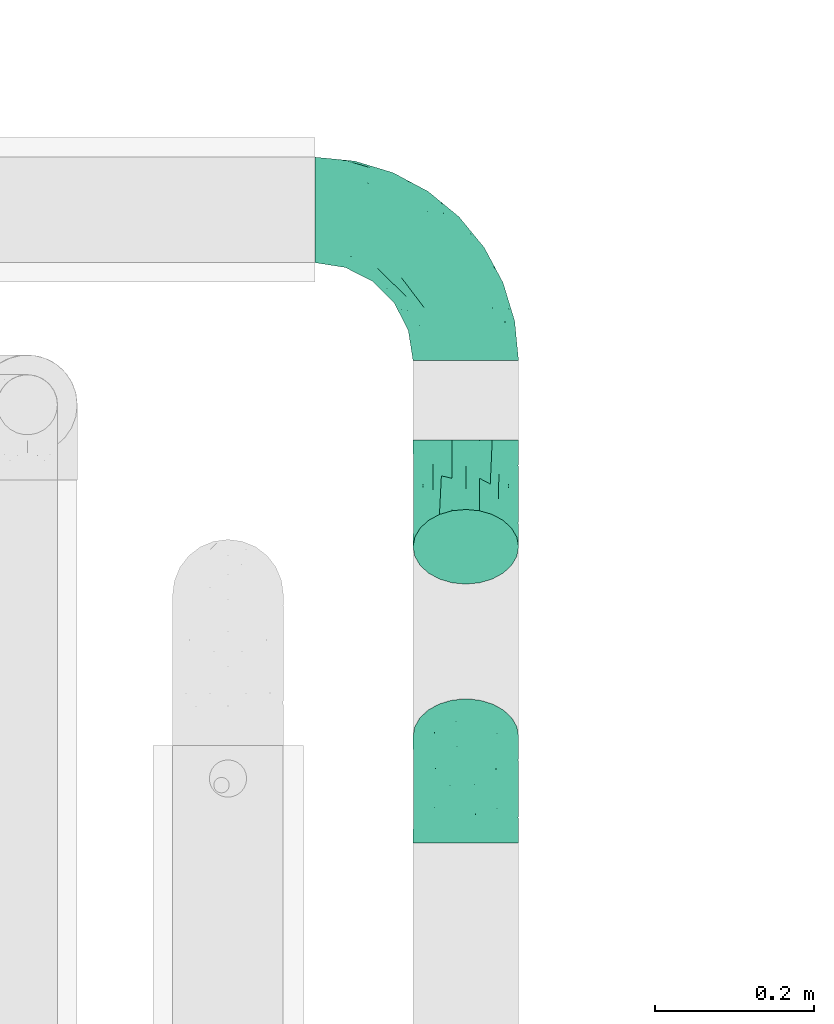
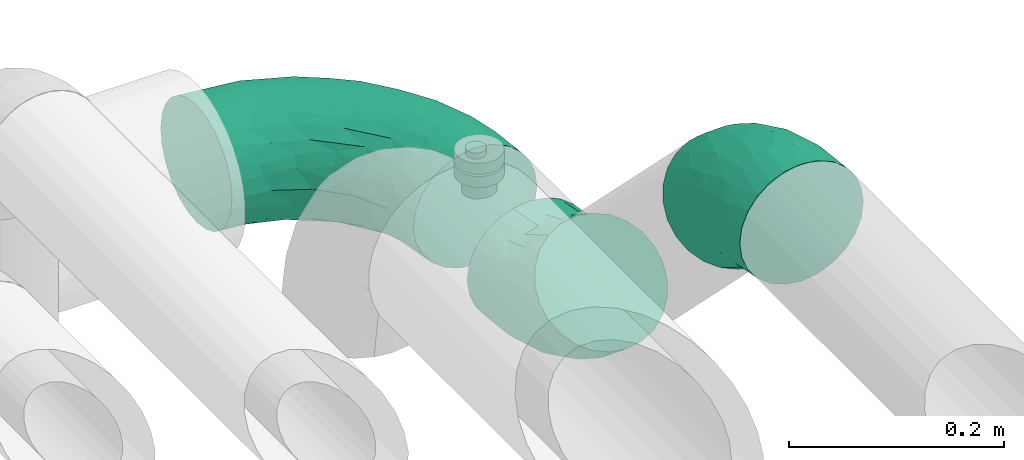
# One storey, part 560 of 827: 3 flow fittings.
"""IFC2X3 building model written with IfcOpenShell, lengths in millimetres."""

from ifc_helpers import new_model, entity, si_unit, converted_unit, derived_unit, direction, frame, origin, place, context, subcontext, project, spatial, faceted_brep, source, transform, mapped, material, type_object, type_shapes, element, save


model = new_model("IFC2X3")

# Units and contexts
model_context = context("Model", 3, precision=0.01, world=origin(), true_north=direction((6.12303176911189e-17, 1.0)))
body_context = subcontext(model_context, "Body", "Model", "MODEL_VIEW")
ifc_project = project(units=[si_unit("LENGTHUNIT", "METRE", prefix="MILLI"), si_unit("AREAUNIT", "SQUARE_METRE"), si_unit("VOLUMEUNIT", "CUBIC_METRE"), converted_unit("PLANEANGLEUNIT", "DEGREE", entity("IfcRatioMeasure", 0.0174532925199433), si_unit("PLANEANGLEUNIT", "RADIAN"), dimensions=[0, 0, 0, 0, 0, 0, 0]), si_unit("MASSUNIT", "GRAM", prefix="KILO"), derived_unit("MASSDENSITYUNIT", [(si_unit("MASSUNIT", "GRAM", prefix="KILO"), 1), (si_unit("LENGTHUNIT", "METRE"), -3)]), derived_unit("MOMENTOFINERTIAUNIT", [(si_unit("LENGTHUNIT", "METRE"), 4)]), si_unit("TIMEUNIT", "SECOND"), si_unit("FREQUENCYUNIT", "HERTZ"), si_unit("THERMODYNAMICTEMPERATUREUNIT", "DEGREE_CELSIUS"), derived_unit("THERMALTRANSMITTANCEUNIT", [(si_unit("MASSUNIT", "GRAM", prefix="KILO"), 1), (si_unit("THERMODYNAMICTEMPERATUREUNIT", "KELVIN"), -1), (si_unit("TIMEUNIT", "SECOND"), -3)]), derived_unit("VOLUMETRICFLOWRATEUNIT", [(si_unit("LENGTHUNIT", "METRE"), 3), (si_unit("TIMEUNIT", "SECOND"), -1)]), derived_unit("MASSFLOWRATEUNIT", [(si_unit("MASSUNIT", "GRAM", prefix="KILO"), 1), (si_unit("TIMEUNIT", "SECOND"), -1)]), derived_unit("ROTATIONALFREQUENCYUNIT", [(si_unit("TIMEUNIT", "SECOND"), -1)]), si_unit("ELECTRICCURRENTUNIT", "AMPERE"), si_unit("ELECTRICVOLTAGEUNIT", "VOLT"), si_unit("POWERUNIT", "WATT"), si_unit("FORCEUNIT", "NEWTON", prefix="KILO"), si_unit("ILLUMINANCEUNIT", "LUX"), si_unit("LUMINOUSFLUXUNIT", "LUMEN"), si_unit("LUMINOUSINTENSITYUNIT", "CANDELA"), derived_unit("USERDEFINED", [(si_unit("MASSUNIT", "GRAM", prefix="KILO"), -1), (si_unit("LENGTHUNIT", "METRE"), -2), (si_unit("TIMEUNIT", "SECOND"), 3), (si_unit("LUMINOUSFLUXUNIT", "LUMEN"), 1)]), derived_unit("LINEARVELOCITYUNIT", [(si_unit("LENGTHUNIT", "METRE"), 1), (si_unit("TIMEUNIT", "SECOND"), -1)]), si_unit("PRESSUREUNIT", "PASCAL"), derived_unit("USERDEFINED", [(si_unit("LENGTHUNIT", "METRE"), -2), (si_unit("MASSUNIT", "GRAM", prefix="KILO"), 1), (si_unit("TIMEUNIT", "SECOND"), -2)]), derived_unit("LINEARFORCEUNIT", [(si_unit("MASSUNIT", "GRAM", prefix="KILO"), 1), (si_unit("LENGTHUNIT", "METRE"), 1), (si_unit("TIMEUNIT", "SECOND"), -2), (si_unit("LENGTHUNIT", "METRE"), -1)]), derived_unit("PLANARFORCEUNIT", [(si_unit("MASSUNIT", "GRAM", prefix="KILO"), 1), (si_unit("LENGTHUNIT", "METRE"), 1), (si_unit("TIMEUNIT", "SECOND"), -2), (si_unit("LENGTHUNIT", "METRE"), -2)])], contexts=[model_context])

# Site, building, storey
site_placement = place(None, origin())
site = spatial("IfcSite", under=ifc_project, at=site_placement, CompositionType="ELEMENT")
building_placement = place(site_placement, origin())
building = spatial("IfcBuilding", under=site, at=building_placement, CompositionType="ELEMENT")
storey_placement = place(building_placement, frame((0.0, 0.0, 28200.0)))
storey = spatial("IfcBuildingStorey", under=building, at=storey_placement, Name="08", CompositionType="ELEMENT", Elevation=28200.0)

# Flow fittings
ifc_material = material()
pipe_fitting_type_1 = type_object("IfcPipeFittingType", Name="ADSK_2", PredefinedType="NOTDEFINED", material=ifc_material)
shared_shape_1 = source(origin(), body_context, "Body", "Brep", [
    faceted_brep([(-190.0, 33.25, -57.59), (-190.0, 17.21, -64.23), (-190.0, 0.0, -66.5), (-190.0, -17.21, -64.23), (-190.0, -33.25, -57.59), (-190.0, -47.02, -47.02), (-190.0, -57.59, -33.25), (-190.0, -64.23, -17.21), (-190.0, -66.5, 0.0), (-190.0, -64.23, 17.21), (-190.0, -57.59, 33.25), (-190.0, -47.02, 47.02), (-190.0, -33.25, 57.59), (-190.0, -17.21, 64.23), (-190.0, 0.0, 66.5), (-190.0, 17.21, 64.23), (-190.0, 33.25, 57.59), (-190.0, 47.02, 47.02), (-190.0, 57.59, 33.25), (-190.0, 64.23, 17.21), (-190.0, 66.5, 0.0), (-190.0, 64.23, -17.21), (-190.0, 57.59, -33.25), (-190.0, 47.02, -47.02), (0.0, 190.0, -66.5), (-17.21, 190.0, -64.23), (-33.25, 190.0, -57.59), (-47.02, 190.0, -47.02), (-57.59, 190.0, -33.25), (-64.23, 190.0, -17.21), (-66.5, 190.0, 0.0), (-64.23, 190.0, 17.21), (-57.59, 190.0, 33.25), (-47.02, 190.0, 47.02), (-33.25, 190.0, 57.59), (-17.21, 190.0, 64.23), (0.0, 190.0, 66.5), (17.21, 190.0, 64.23), (33.25, 190.0, 57.59), (47.02, 190.0, 47.02), (57.59, 190.0, 33.25), (64.23, 190.0, 17.21), (66.5, 190.0, 0.0), (64.23, 190.0, -17.21), (57.59, 190.0, -33.25), (47.02, 190.0, -47.02), (33.25, 190.0, -57.59), (17.21, 190.0, -64.23), (-28.55, 147.02, 62.42), (-13.57, 135.63, 66.28), (-140.38, -49.33, 38.23), (-80.14, -30.55, 35.23), (-124.14, -33.9, 50.4), (-141.11, -22.46, 60.31), (-81.84, -6.19, 57.13), (-101.3, 6.38, 65.03), (-125.04, -54.28, 21.95), (-139.96, -61.57, 0.0), (-30.59, -6.47, 21.28), (-47.5, -23.27, 0.0), (-8.63, 8.63, 0.0), (-101.64, 52.37, 61.01), (-147.02, 28.55, 62.42), (-107.01, 35.47, 64.88), (-72.79, -35.94, 16.05), (-91.84, -46.98, 0.0), (-42.05, -7.73, 34.33), (-4.24, 27.9, 35.0), (-46.26, 0.22, 45.96), (-148.38, -6.74, 65.57), (-135.63, 13.57, 66.28), (-58.81, 143.49, 42.9), (-64.43, 158.86, 27.32), (33.87, 124.03, 50.39), (-24.86, 95.88, 66.5), (-6.38, 101.3, 65.03), (-68.44, 29.45, 65.52), (-33.12, 50.38, 63.42), (-47.55, 58.11, 66.37), (-68.78, 157.93, 15.75), (-78.73, 128.81, 21.25), (-145.19, 58.3, 42.81), (-126.57, 73.12, 34.22), (-158.86, 64.43, 27.32), (-157.93, 68.78, 15.75), (-73.06, 126.96, 34.0), (-99.23, 99.23, 24.99), (-94.51, 94.51, 37.44), (-160.28, 41.89, 53.91), (-151.84, 72.54, 0.0), (-128.81, 78.73, 21.25), (-117.41, 90.09, 0.0), (7.42, 29.34, 16.05), (36.05, 72.53, 15.16), (23.27, 47.5, 0.0), (30.73, 80.34, 35.12), (61.57, 139.96, 0.0), (62.07, 150.38, 13.25), (46.98, 91.84, 0.0), (22.46, 141.08, 60.31), (6.16, 81.82, 57.15), (-39.4, 100.2, 64.86), (54.07, 123.33, 21.27), (49.32, 140.35, 38.22), (-83.36, -19.52, 48.87), (6.74, 148.38, 65.57), (-85.07, 81.39, 53.88), (-123.92, 51.92, 55.31), (-90.09, 117.41, 0.0), (-72.54, 151.84, 0.0), (-101.92, 101.92, 11.85), (-42.36, 157.28, 54.02), (-54.08, 118.94, 55.5), (-1.97, 47.81, 48.28), (22.27, 83.36, 46.49), (-79.1, 73.18, 59.88), (-73.69, 63.3, 64.01), (-96.26, 24.55, 66.5), (-73.56, 111.53, 44.32), (-111.08, 72.88, 45.21), (-31.39, 31.39, 56.96), (-71.89, 12.15, 62.21), (-42.48, 117.92, 61.28), (-157.28, 42.36, -54.02), (-72.79, -35.94, -16.05), (-44.48, -10.39, -33.14), (-30.59, -6.47, -21.28), (-101.3, 6.38, -65.03), (-148.38, -6.74, -65.57), (-135.63, 13.57, -66.28), (-157.93, 68.78, -15.75), (-128.81, 78.73, -21.25), (-158.86, 64.43, -27.32), (-147.02, 28.55, -62.42), (-100.2, 39.4, -64.86), (-95.88, 24.86, -66.5), (-150.3, -62.06, -13.27), (-101.92, 101.92, -11.85), (-143.49, 58.81, -42.9), (6.74, 148.38, -65.57), (-13.57, 135.63, -66.28), (-52.37, 101.64, -61.01), (-81.39, 85.07, -53.88), (-51.92, 123.92, -55.31), (-124.14, -33.9, -50.4), (-81.84, -6.19, -57.13), (-78.6, -18.73, -47.44), (-140.38, -49.33, -38.23), (-24.55, 96.26, -66.5), (-35.47, 107.01, -64.88), (-28.55, 147.02, -62.42), (-80.14, -30.55, -35.23), (-123.37, -54.04, -21.36), (-64.43, 158.86, -27.32), (-68.78, 157.93, -15.75), (-73.18, 79.1, -59.88), (-63.3, 73.69, -64.01), (-29.45, 68.44, -65.52), (-50.38, 33.12, -63.42), (-58.11, 47.55, -66.37), (-78.73, 128.81, -21.25), (-99.23, 99.23, -24.99), (-126.96, 73.06, -34.0), (-94.51, 94.51, -37.44), (-58.3, 145.19, -42.81), (-73.12, 126.57, -34.22), (-118.94, 54.08, -55.5), (-41.89, 160.28, -53.91), (22.46, 141.08, -60.31), (6.16, 81.82, -57.15), (-6.38, 101.3, -65.03), (33.87, 124.03, -50.39), (54.35, 125.32, -21.97), (35.86, 72.99, -16.69), (49.34, 140.46, -38.23), (7.54, 29.16, -15.21), (-141.11, -22.46, -60.31), (30.73, 80.34, -35.12), (22.8, 84.14, -46.35), (-4.38, 23.43, -29.89), (5.33, 47.62, -41.81), (-111.53, 73.56, -44.32), (-72.88, 111.08, -45.21), (-48.51, 2.91, -49.35), (-20.15, 28.66, -49.63), (-27.46, 10.86, -41.59), (-12.16, 71.91, -62.22), (2.48, 58.84, -50.8), (-117.92, 42.48, -61.28), (-31.39, 31.39, -56.96)], [[[0, 1, 2, 3, 4, 5, 6, 7, 8, 9, 10, 11, 12, 13, 14, 15, 16, 17, 18, 19, 20, 21, 22, 23]], [[24, 25, 26, 27, 28, 29, 30, 31, 32, 33, 34, 35, 36, 37, 38, 39, 40, 41, 42, 43, 44, 45, 46, 47]], [[35, 48, 49]], [[50, 51, 52]], [[53, 54, 55]], [[56, 10, 9]], [[9, 8, 57]], [[58, 59, 60]], [[56, 50, 10]], [[61, 62, 63]], [[64, 65, 59]], [[58, 64, 59]], [[12, 11, 52]], [[66, 67, 68]], [[52, 53, 12]], [[69, 70, 14]], [[71, 32, 72]], [[73, 39, 38]], [[49, 74, 75]], [[62, 16, 15]], [[14, 70, 15]], [[72, 32, 31]], [[13, 69, 14]], [[76, 77, 78]], [[79, 80, 72]], [[81, 82, 83]], [[62, 15, 70]], [[20, 19, 84]], [[85, 86, 87]], [[81, 17, 88]], [[89, 90, 91]], [[19, 83, 84]], [[16, 88, 17]], [[85, 71, 72]], [[58, 60, 92]], [[49, 36, 35]], [[93, 92, 94]], [[35, 34, 48]], [[92, 93, 95]], [[96, 97, 98]], [[73, 99, 100]], [[49, 101, 74]], [[102, 97, 40]], [[39, 73, 103]], [[95, 102, 103]], [[40, 39, 103]], [[12, 53, 13]], [[68, 54, 104]], [[42, 97, 96]], [[41, 97, 42]], [[99, 38, 37]], [[37, 36, 105]], [[61, 106, 107]], [[108, 80, 109]], [[10, 50, 11]], [[108, 91, 110]], [[109, 79, 30]], [[64, 51, 56]], [[71, 33, 32]], [[86, 110, 90]], [[92, 60, 94]], [[111, 34, 33]], [[71, 112, 111]], [[49, 48, 101]], [[9, 57, 56]], [[17, 81, 18]], [[65, 56, 57]], [[113, 114, 100]], [[75, 105, 49]], [[115, 61, 116]], [[58, 92, 67]], [[99, 73, 38]], [[70, 117, 63]], [[18, 83, 19]], [[71, 85, 118]], [[119, 107, 106]], [[83, 82, 90]], [[51, 50, 56]], [[52, 11, 50]], [[51, 64, 58]], [[56, 65, 64]], [[94, 98, 93]], [[67, 92, 95]], [[95, 114, 113]], [[68, 120, 54]], [[54, 53, 52]], [[69, 53, 55]], [[104, 51, 68]], [[121, 76, 55]], [[103, 73, 114]], [[102, 40, 103]], [[105, 99, 37]], [[75, 77, 100]], [[75, 100, 99]], [[100, 120, 113]], [[111, 48, 34]], [[115, 101, 122]], [[122, 101, 48]], [[101, 116, 78]], [[116, 63, 117]], [[78, 117, 76]], [[63, 62, 70]], [[88, 62, 107]], [[98, 102, 93]], [[95, 93, 102]], [[66, 68, 51]], [[113, 68, 67]], [[49, 105, 36]], [[99, 105, 75]], [[53, 69, 13]], [[70, 69, 55]], [[70, 55, 117]], [[61, 63, 116]], [[76, 117, 55]], [[116, 117, 78]], [[121, 55, 54]], [[76, 121, 77]], [[100, 77, 120]], [[75, 78, 77]], [[54, 120, 121]], [[77, 121, 120]], [[71, 111, 33]], [[111, 112, 122]], [[68, 113, 120]], [[95, 113, 67]], [[61, 115, 106]], [[62, 61, 107]], [[118, 112, 71]], [[119, 87, 82]], [[101, 115, 116]], [[112, 106, 115]], [[79, 72, 31]], [[72, 80, 85]], [[86, 85, 80]], [[118, 85, 87]], [[119, 118, 87]], [[112, 118, 106]], [[30, 79, 31]], [[109, 80, 79]], [[81, 83, 18]], [[84, 83, 90]], [[119, 82, 81]], [[86, 82, 87]], [[107, 119, 81]], [[118, 119, 106]], [[90, 89, 84]], [[20, 84, 89]], [[62, 88, 16]], [[81, 88, 107]], [[101, 78, 74]], [[78, 75, 74]], [[80, 108, 110]], [[82, 86, 90]], [[90, 110, 91]], [[80, 110, 86]], [[40, 97, 41]], [[98, 97, 102]], [[111, 122, 48]], [[115, 122, 112]], [[54, 52, 104]], [[51, 104, 52]], [[51, 58, 66]], [[67, 66, 58]], [[103, 114, 95]], [[100, 114, 73]], [[23, 123, 0]], [[124, 125, 126]], [[127, 128, 129]], [[130, 131, 132]], [[133, 134, 129]], [[129, 135, 127]], [[89, 130, 20]], [[8, 136, 57]], [[91, 131, 89]], [[59, 65, 124]], [[108, 137, 91]], [[132, 22, 21]], [[138, 23, 22]], [[139, 140, 24]], [[141, 142, 143]], [[144, 145, 146]], [[5, 144, 147]], [[140, 148, 149]], [[8, 7, 136]], [[138, 22, 132]], [[6, 5, 147]], [[141, 150, 149]], [[147, 151, 152]], [[152, 136, 6]], [[29, 153, 154]], [[125, 124, 151]], [[136, 65, 57]], [[155, 141, 156]], [[128, 3, 2]], [[126, 59, 124]], [[129, 134, 135]], [[157, 158, 159]], [[160, 161, 137]], [[1, 0, 133]], [[129, 2, 1]], [[162, 138, 132]], [[161, 163, 162]], [[154, 30, 29]], [[144, 5, 4]], [[153, 164, 165]], [[150, 26, 25]], [[166, 123, 138]], [[24, 47, 139]], [[24, 140, 25]], [[28, 153, 29]], [[26, 167, 27]], [[168, 169, 170]], [[140, 150, 25]], [[27, 164, 28]], [[46, 171, 168]], [[172, 98, 173]], [[59, 126, 60]], [[27, 167, 164]], [[44, 174, 45]], [[173, 98, 94]], [[175, 173, 94]], [[176, 144, 4]], [[171, 46, 45]], [[44, 43, 172]], [[43, 96, 172]], [[42, 96, 43]], [[144, 146, 151]], [[144, 176, 145]], [[177, 178, 174]], [[173, 175, 179]], [[44, 172, 174]], [[98, 172, 96]], [[1, 133, 129]], [[179, 180, 177]], [[109, 160, 108]], [[46, 168, 47]], [[176, 4, 3]], [[138, 162, 181]], [[182, 143, 142]], [[153, 165, 160]], [[94, 60, 175]], [[177, 172, 173]], [[151, 147, 144]], [[152, 6, 147]], [[128, 176, 3]], [[127, 158, 145]], [[127, 145, 176]], [[183, 184, 185]], [[65, 152, 124]], [[151, 124, 152]], [[177, 174, 172]], [[171, 45, 174]], [[169, 168, 171]], [[139, 168, 170]], [[178, 177, 180]], [[186, 157, 170]], [[187, 169, 178]], [[126, 179, 175]], [[123, 133, 0]], [[155, 134, 188]], [[188, 134, 133]], [[134, 156, 159]], [[156, 149, 148]], [[159, 148, 157]], [[149, 150, 140]], [[167, 150, 143]], [[60, 126, 175]], [[125, 179, 126]], [[129, 128, 2]], [[176, 128, 127]], [[168, 139, 47]], [[140, 139, 170]], [[140, 170, 148]], [[141, 149, 156]], [[157, 148, 170]], [[156, 148, 159]], [[186, 170, 169]], [[157, 186, 158]], [[145, 158, 189]], [[127, 159, 158]], [[169, 189, 186]], [[158, 186, 189]], [[180, 179, 185]], [[173, 179, 177]], [[187, 184, 189]], [[178, 171, 174]], [[187, 178, 180]], [[169, 171, 178]], [[184, 180, 185]], [[189, 169, 187]], [[138, 123, 23]], [[123, 166, 188]], [[141, 155, 142]], [[150, 141, 143]], [[181, 166, 138]], [[182, 163, 165]], [[134, 155, 156]], [[166, 142, 155]], [[130, 132, 21]], [[132, 131, 162]], [[161, 162, 131]], [[181, 162, 163]], [[182, 181, 163]], [[166, 181, 142]], [[20, 130, 21]], [[89, 131, 130]], [[164, 153, 28]], [[154, 153, 160]], [[182, 165, 164]], [[161, 165, 163]], [[143, 182, 164]], [[181, 182, 142]], [[160, 109, 154]], [[30, 154, 109]], [[150, 167, 26]], [[164, 167, 143]], [[134, 159, 135]], [[159, 127, 135]], [[131, 91, 137]], [[165, 161, 160]], [[160, 137, 108]], [[131, 137, 161]], [[6, 136, 7]], [[65, 136, 152]], [[183, 189, 184]], [[146, 183, 125]], [[146, 125, 151]], [[179, 125, 185]], [[123, 188, 133]], [[155, 188, 166]], [[180, 184, 187]], [[185, 125, 183]], [[146, 145, 183]], [[189, 183, 145]]]),
])
type_shapes(pipe_fitting_type_1, [shared_shape_1])
flow_fitting_placement = place(storey_placement, frame((27420.03, 12315.57, 3100.0), z_axis=(0.0, 0.0, 1.0), x_axis=(0.0, 1.0, 0.0)))
element("IfcFlowFitting", 1, at=flow_fitting_placement, inside=storey, type_object=pipe_fitting_type_1, material=ifc_material, Name="ADSK_2", ObjectType="ADSK_2", context=body_context, shape_type="MappedRepresentation", body=[
    mapped(shared_shape_1, transform((0.0, 0.0, 0.0), scale=1.0)),
])
pipe_fitting_type_2 = type_object("IfcPipeFittingType", Name="ADSK_2", PredefinedType="NOTDEFINED", material=ifc_material)
shared_shape_2 = source(origin(), body_context, "Body", "Brep", [
    faceted_brep([(-78.7, 33.25, -57.59), (-78.7, 17.21, -64.23), (-78.7, 0.0, -66.5), (-78.7, -17.21, -64.23), (-78.7, -33.25, -57.59), (-78.7, -47.02, -47.02), (-78.7, -57.59, -33.25), (-78.7, -64.23, -17.21), (-78.7, -66.5, 0.0), (-78.7, -64.23, 17.21), (-78.7, -57.59, 33.25), (-78.7, -47.02, 47.02), (-78.7, -33.25, 57.59), (-78.7, -17.21, 64.23), (-78.7, 0.0, 66.5), (-78.7, 17.21, 64.23), (-78.7, 33.25, 57.59), (-78.7, 47.02, 47.02), (-78.7, 57.59, 33.25), (-78.7, 64.23, 17.21), (-78.7, 66.5, 0.0), (-78.7, 64.23, -17.21), (-78.7, 57.59, -33.25), (-78.7, 47.02, -47.02), (55.65, 55.65, -66.5), (43.48, 67.82, -64.23), (32.14, 79.16, -57.59), (22.4, 88.9, -47.02), (14.93, 96.37, -33.25), (10.23, 101.07, -17.21), (8.63, 102.67, 0.0), (10.23, 101.07, 17.21), (14.93, 96.37, 33.25), (22.4, 88.9, 47.02), (32.14, 79.16, 57.59), (43.48, 67.82, 64.23), (55.65, 55.65, 66.5), (67.82, 43.48, 64.23), (79.16, 32.14, 57.59), (88.9, 22.4, 47.02), (96.37, 14.93, 33.25), (101.07, 10.23, 17.21), (102.67, 8.63, 0.0), (101.07, 10.23, -17.21), (96.37, 14.93, -33.25), (88.9, 22.4, -47.02), (79.16, 32.14, -57.59), (67.82, 43.48, -64.23), (-40.01, -57.38, 27.86), (-40.6, -61.75, 15.74), (-6.41, -52.87, 20.07), (-28.66, -61.57, 0.0), (44.74, 12.16, 61.0), (-23.71, -35.12, 51.77), (8.73, -21.07, 54.25), (-40.23, -23.04, 61.0), (-34.61, -49.5, 39.47), (-28.9, -3.87, 65.72), (-8.47, 20.45, 66.18), (-47.15, 10.46, 66.05), (-49.81, 55.22, 41.25), (-33.77, 66.88, 30.79), (-20.88, 50.42, 53.92), (7.4, 48.4, 61.91), (-34.71, 30.07, 61.97), (42.4, -35.06, 11.04), (19.46, -46.98, 0.0), (63.8, -23.27, 0.0), (-15.18, 67.35, 41.6), (14.82, -35.78, 38.27), (53.98, -24.32, 23.88), (-30.55, 73.76, 17.41), (-46.74, 70.71, 0.0), (59.47, -10.53, 39.47), (-16.95, 83.05, 0.0), (25.95, 40.74, 66.05), (41.59, -8.07, 51.77), (23.18, 17.7, 65.72), (74.36, -14.41, 12.26), (4.62, -11.15, 60.44), (-39.45, 28.99, -61.91), (-20.88, 50.42, -53.92), (3.28, 45.81, -61.97), (-23.41, 71.18, -30.79), (8.73, -21.07, -54.25), (4.62, -11.15, -60.44), (44.74, 12.16, -61.0), (-30.55, 73.76, -17.41), (-40.23, -23.04, -61.0), (-23.71, -35.12, -51.77), (-36.89, 58.36, -41.6), (-47.15, 10.46, -66.05), (-28.9, -3.87, -65.72), (-20.98, -55.37, -23.88), (-34.61, -49.5, -39.47), (68.86, -12.28, -27.86), (59.47, -10.53, -39.47), (-42.39, -62.77, -12.26), (41.59, -8.07, -51.77), (14.82, -35.78, -38.27), (41.92, -32.85, -20.07), (-5.19, -54.78, -11.04), (72.37, -14.95, -15.74), (-3.83, 74.27, -41.25), (25.95, 40.74, -66.05), (23.18, 17.7, -65.72), (-8.47, 20.45, -66.18)], [[[0, 1, 2, 3, 4, 5, 6, 7, 8, 9, 10, 11, 12, 13, 14, 15, 16, 17, 18, 19, 20, 21, 22, 23]], [[24, 25, 26, 27, 28, 29, 30, 31, 32, 33, 34, 35, 36, 37, 38, 39, 40, 41, 42, 43, 44, 45, 46, 47]], [[48, 49, 50]], [[49, 8, 51]], [[38, 37, 52]], [[12, 11, 53]], [[53, 54, 55]], [[56, 11, 10]], [[14, 13, 57]], [[13, 12, 55]], [[57, 58, 59]], [[60, 61, 18]], [[62, 63, 34]], [[18, 61, 19]], [[16, 15, 64]], [[17, 16, 62]], [[65, 66, 67]], [[60, 62, 68]], [[15, 14, 59]], [[34, 33, 62]], [[69, 50, 70]], [[19, 71, 72]], [[40, 39, 73]], [[72, 20, 19]], [[74, 71, 31]], [[50, 66, 65]], [[62, 16, 64]], [[56, 48, 69]], [[66, 50, 51]], [[36, 35, 75]], [[39, 38, 76]], [[76, 73, 39]], [[32, 31, 61]], [[75, 77, 36]], [[70, 41, 40]], [[77, 37, 36]], [[48, 56, 10]], [[70, 40, 73]], [[59, 64, 15]], [[76, 38, 52]], [[58, 75, 63]], [[42, 41, 78]], [[53, 56, 69]], [[17, 60, 18]], [[54, 79, 55]], [[72, 71, 74]], [[48, 9, 49]], [[30, 74, 31]], [[54, 69, 76]], [[31, 71, 61]], [[58, 57, 77]], [[32, 68, 33]], [[55, 57, 13]], [[68, 62, 33]], [[79, 52, 77]], [[35, 34, 63]], [[63, 62, 64]], [[73, 76, 69]], [[79, 77, 57]], [[78, 70, 65]], [[70, 73, 69]], [[56, 53, 11]], [[58, 63, 64]], [[53, 55, 12]], [[57, 55, 79]], [[77, 52, 37]], [[52, 79, 54]], [[57, 59, 14]], [[64, 59, 58]], [[63, 75, 35]], [[77, 75, 58]], [[62, 60, 17]], [[61, 60, 68]], [[32, 61, 68]], [[61, 71, 19]], [[9, 48, 10]], [[69, 48, 50]], [[8, 49, 9]], [[51, 50, 49]], [[78, 65, 67]], [[50, 65, 70]], [[42, 78, 67]], [[70, 78, 41]], [[69, 54, 53]], [[52, 54, 76]], [[1, 0, 80]], [[81, 82, 80]], [[28, 83, 29]], [[23, 81, 0]], [[20, 72, 21]], [[84, 85, 86]], [[21, 87, 83]], [[88, 89, 4]], [[81, 23, 90]], [[91, 92, 2]], [[26, 25, 82]], [[91, 2, 1]], [[93, 6, 94]], [[95, 96, 44]], [[8, 7, 97]], [[81, 80, 0]], [[93, 7, 6]], [[98, 96, 99]], [[88, 4, 3]], [[100, 66, 101]], [[6, 5, 94]], [[89, 5, 4]], [[2, 92, 3]], [[94, 89, 99]], [[93, 94, 99]], [[96, 98, 45]], [[87, 72, 74]], [[89, 94, 5]], [[74, 30, 29]], [[99, 100, 93]], [[72, 87, 21]], [[95, 43, 102]], [[103, 83, 28]], [[90, 103, 81]], [[26, 82, 81]], [[46, 45, 98]], [[104, 25, 24]], [[96, 95, 99]], [[22, 90, 23]], [[26, 81, 27]], [[84, 99, 89]], [[104, 105, 106]], [[84, 86, 98]], [[27, 103, 28]], [[24, 47, 105]], [[67, 66, 100]], [[44, 96, 45]], [[47, 46, 86]], [[100, 95, 102]], [[85, 92, 105]], [[67, 102, 42]], [[85, 88, 92]], [[106, 105, 92]], [[97, 93, 101]], [[22, 21, 83]], [[101, 66, 51]], [[104, 82, 25]], [[87, 74, 29]], [[106, 91, 80]], [[86, 105, 47]], [[106, 80, 82]], [[92, 88, 3]], [[88, 85, 84]], [[98, 86, 46]], [[105, 86, 85]], [[80, 91, 1]], [[92, 91, 106]], [[105, 104, 24]], [[82, 104, 106]], [[81, 103, 27]], [[83, 103, 90]], [[22, 83, 90]], [[83, 87, 29]], [[43, 95, 44]], [[99, 95, 100]], [[42, 102, 43]], [[67, 100, 102]], [[97, 101, 51]], [[100, 101, 93]], [[8, 97, 51]], [[93, 97, 7]], [[99, 84, 98]], [[88, 84, 89]]]),
])
type_shapes(pipe_fitting_type_2, [shared_shape_2])
for number, where, z_axis, x_axis, name in (
    (2, (27420.03, 11946.76, 3100.0), (-1.0, 0.0, 0.0), (0.0, -1.0, 0.0), "ADSK_2"),
    (3, (27420.03, 11596.76, 3450.0), (1.0, 0.0, 0.0), (0.0, -0.707106781186515, 0.70710678118658), "ADSK_2"),
):
    element("IfcFlowFitting", number, at=place(storey_placement, frame(where, z_axis=z_axis, x_axis=x_axis)), inside=storey, type_object=pipe_fitting_type_2, material=ifc_material, Name=name, ObjectType="ADSK_2", context=body_context, shape_type="MappedRepresentation", body=[
        mapped(shared_shape_2, transform((0.0, 0.0, 0.0), scale=1.0)),
    ])

save(model, "model.ifc")
